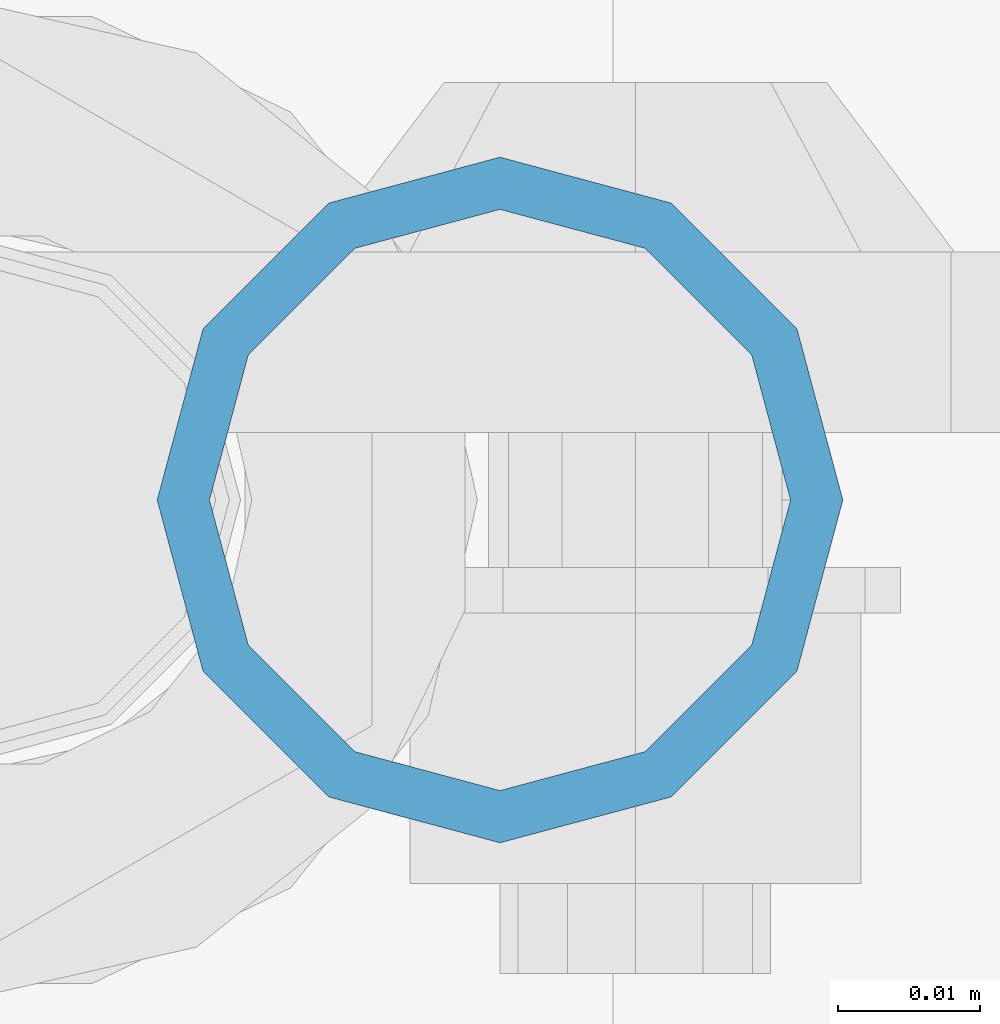
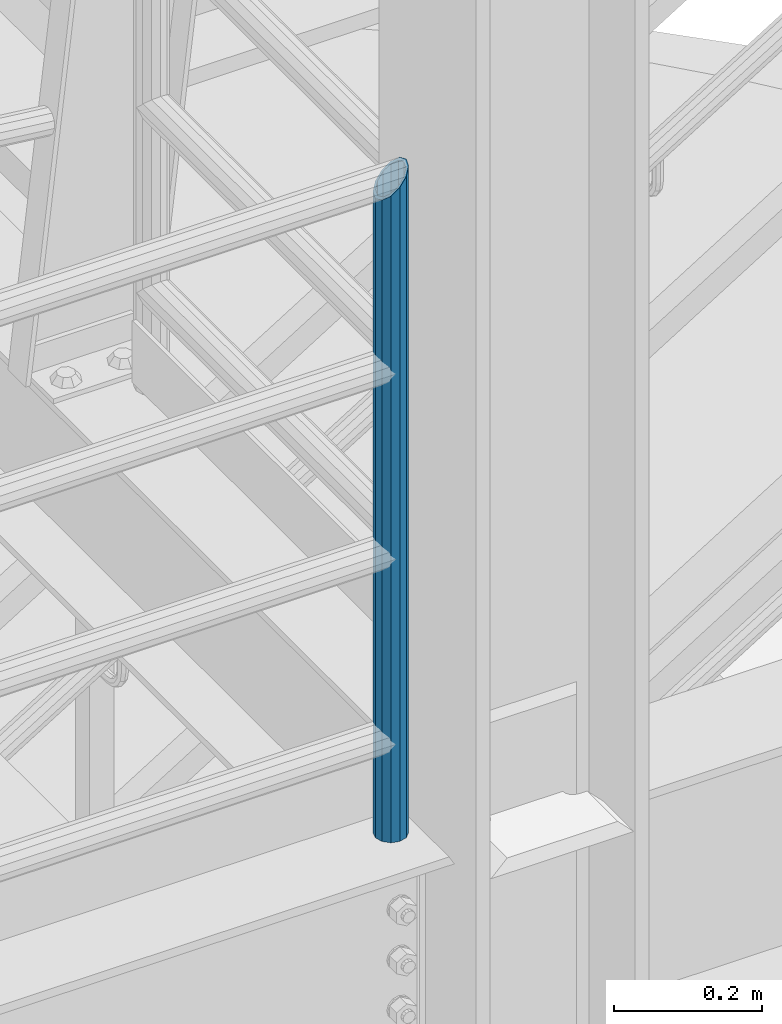
# One storey, part 561 of 1876: 1 column, 1 element without a shape of its own.
"""IFC2X3 building model written with IfcOpenShell, lengths in millimetres."""

from ifc_helpers import new_model, si_unit, frame, origin_with_axes, place, context, subcontext, project, spatial, faceted_brep, material, type_object, element, aggregate, save


model = new_model("IFC2X3")

# Units and contexts
model_context = context("Model", 3, precision=1e-05, world=origin_with_axes())
body_context = subcontext(model_context, "Body", "Model", "MODEL_VIEW")
ifc_project = project(units=[si_unit("LENGTHUNIT", "METRE", prefix="MILLI"), si_unit("AREAUNIT", "SQUARE_METRE"), si_unit("VOLUMEUNIT", "CUBIC_METRE"), si_unit("MASSUNIT", "GRAM", prefix="KILO"), si_unit("TIMEUNIT", "SECOND"), si_unit("PLANEANGLEUNIT", "RADIAN"), si_unit("SOLIDANGLEUNIT", "STERADIAN"), si_unit("THERMODYNAMICTEMPERATUREUNIT", "DEGREE_CELSIUS"), si_unit("LUMINOUSINTENSITYUNIT", "LUMEN")], contexts=[model_context])

# Site, building, storey
site_placement = place(None, origin_with_axes())
site = spatial("IfcSite", under=ifc_project, at=site_placement, CompositionType="ELEMENT")
building_placement = place(site_placement, origin_with_axes())
building = spatial("IfcBuilding", under=site, at=building_placement, Name="Undefined", CompositionType="ELEMENT")
storey_placement = place(building_placement, origin_with_axes())
storey = spatial("IfcBuildingStorey", under=building, at=storey_placement, Name="Undefined", CompositionType="ELEMENT", Elevation=0.0)

# Assembly, column
assembly_placement = place(storey_placement, origin_with_axes())
assembly = element("IfcElementAssembly", 1, at=assembly_placement, inside=storey, Name="RAIL", AssemblyPlace="NOTDEFINED", PredefinedType="RIGID_FRAME")
ifc_material = material()
column_type = type_object("IfcColumnType", Name="PIPE1-1/2SCH40", PredefinedType="NOTDEFINED")
column_placement = place(assembly_placement, frame((1535.1125, -7112.0, 17983.2), z_axis=(0.0, 1.0, 0.0), x_axis=(0.0, 0.0, 1.0)))
column = element("IfcColumn", 2, at=column_placement, type_object=column_type, material=ifc_material, Name="POST", ObjectType="PIPE1-1/2SCH40", context=body_context, shape_type="Brep", body=[
    faceted_brep([(0.0, -20.4469999999999, 0.0), (0.0, -17.7076214311803, 10.2235000000001), (1058.61737856882, -17.7076214311803, 10.2235000000001), (1055.878, -20.4469999999999, 0.0), (0.0, -10.2235000000001, 17.7076214311801), (1066.1015, -10.2235000000001, 17.7076214311801), (-1.45519152283669e-11, 0.0, 20.4470000000001), (1076.325, 0.0, 20.4470000000001), (0.0, 10.2235000000001, 17.7076214311801), (1086.5485, 10.2235000000001, 17.7076214311801), (0.0, 17.7076214311803, 10.2235000000001), (1094.03262143118, 17.7076214311803, 10.2235000000001), (0.0, 20.4469999999999, 0.0), (1096.772, 20.4469999999999, 0.0), (0.0, 17.7076214311803, -10.2235000000001), (1094.03262143118, 17.7076214311803, -10.2235000000001), (0.0, 10.2235000000001, -17.7076214311801), (1086.5485, 10.2235000000001, -17.7076214311801), (-1.45519152283669e-11, 0.0, -20.4470000000001), (1076.325, 0.0, -20.4470000000001), (0.0, -10.2235000000001, -17.7076214311801), (1066.1015, -10.2235000000001, -17.7076214311801), (0.0, -17.7076214311803, -10.2235000000001), (1058.61737856882, -17.7076214311803, -10.2235000000001), (0.0, -24.1299999999992, 0.0), (0.0, -20.8971929933184, -12.0649999999996), (1055.42780700668, -20.8971929933184, -12.0649999999996), (1052.195, -24.1300000000001, 0.0), (0.0, -12.0650000000001, -20.8971929933186), (1064.26, -12.0650000000001, -20.8971929933186), (-1.45519152283669e-11, 0.0, -24.130000000001), (1076.325, 0.0, -24.1300000000001), (0.0, 12.0650000000001, -20.8971929933186), (1088.39, 12.0650000000001, -20.8971929933186), (0.0, 20.8971929933184, -12.0649999999996), (1097.22219299332, 20.8971929933184, -12.0649999999996), (0.0, 24.1299999999992, 0.0), (1100.455, 24.1300000000001, 0.0), (0.0, 20.8971929933184, 12.0649999999996), (1097.22219299332, 20.8971929933184, 12.0649999999996), (0.0, 12.0650000000001, 20.8971929933186), (1088.39, 12.0650000000001, 20.8971929933186), (-1.45519152283669e-11, 0.0, 24.130000000001), (1076.325, 0.0, 24.1300000000001), (0.0, -12.0650000000001, 20.8971929933186), (1064.26, -12.0650000000001, 20.8971929933186), (0.0, -20.8971929933184, 12.0649999999996), (1055.42780700668, -20.8971929933184, 12.0649999999996)], [[[0, 1, 2, 3]], [[1, 4, 5, 2]], [[4, 6, 7, 5]], [[6, 8, 9, 7]], [[8, 10, 11, 9]], [[10, 12, 13, 11]], [[12, 14, 15, 13]], [[14, 16, 17, 15]], [[16, 18, 19, 17]], [[18, 20, 21, 19]], [[20, 22, 23, 21]], [[22, 0, 3, 23]], [[24, 25, 26, 27]], [[25, 28, 29, 26]], [[28, 30, 31, 29]], [[30, 32, 33, 31]], [[32, 34, 35, 33]], [[34, 36, 37, 35]], [[36, 38, 39, 37]], [[38, 40, 41, 39]], [[40, 42, 43, 41]], [[42, 44, 45, 43]], [[44, 46, 47, 45]], [[46, 24, 27, 47]], [[29, 31, 33, 35, 37, 39, 41, 43, 45, 47, 27, 26], [5, 7, 9, 11, 13, 15, 17, 19, 21, 23, 3, 2]], [[46, 44, 42, 40, 38, 36, 34, 32, 30, 28, 25, 24], [22, 20, 18, 16, 14, 12, 10, 8, 6, 4, 1, 0]]]),
])
aggregate(assembly, [column])

save(model, "model.ifc")
